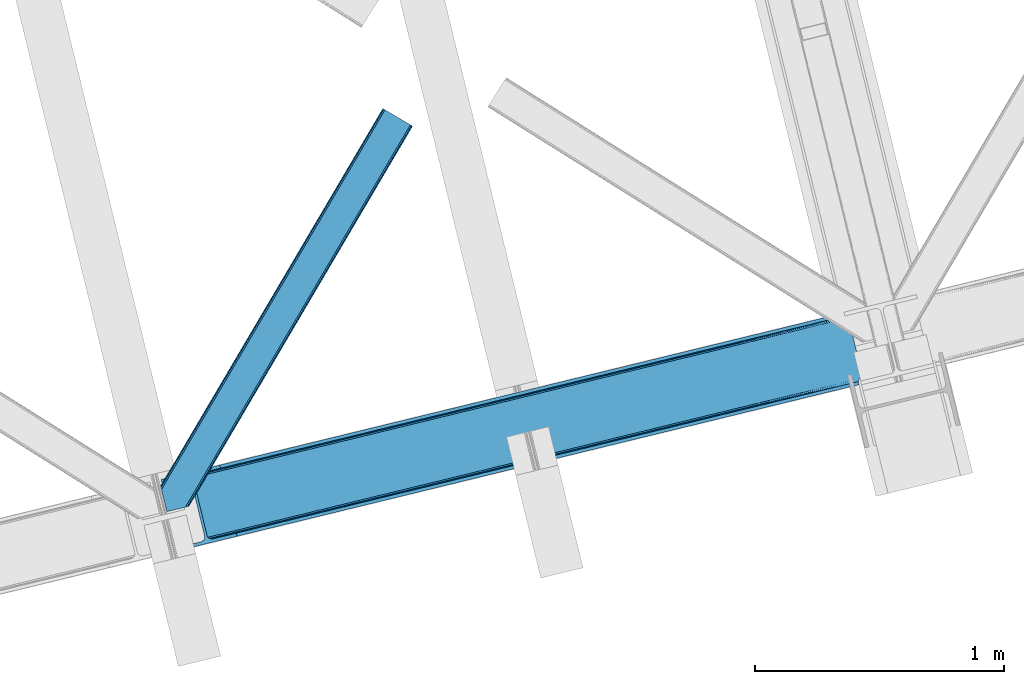
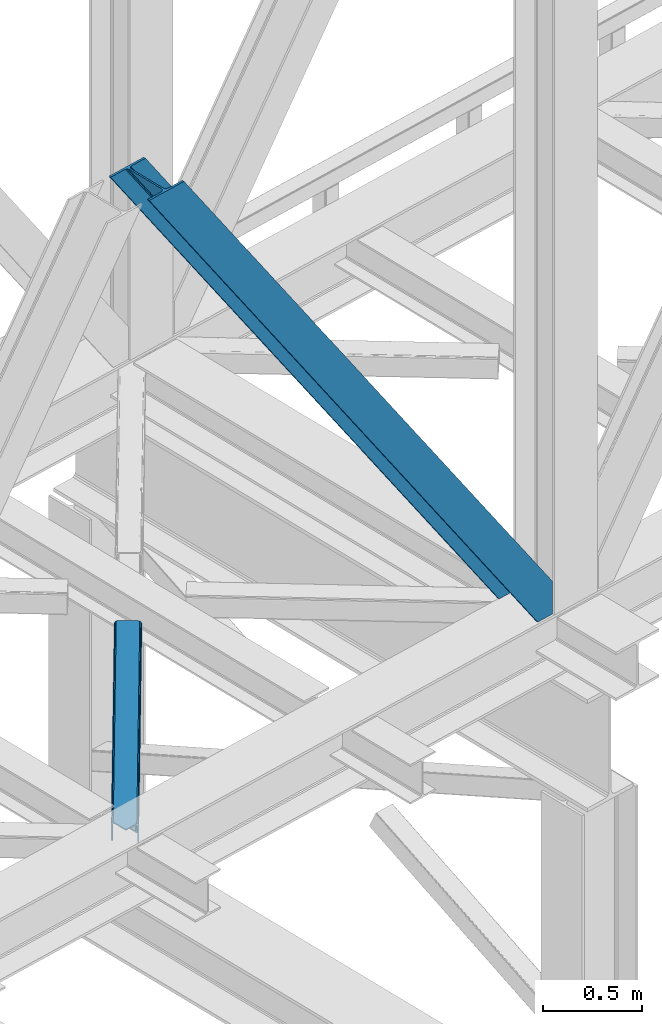
# One storey, part 28 of 92: 2 members.
"""IFC4 building model written with IfcOpenShell, lengths in millimetres."""

from ifc_helpers import new_model, entity, si_unit, converted_unit, derived_unit, direction, frame, origin, place, context, subcontext, project, spatial, triangles, type_object, element, save


model = new_model("IFC4")

# Units and contexts
model_context = context("Model", 3, precision=0.01, world=origin(), true_north=direction((6.12303176911189e-17, 1.0)))
plan_context = context("Plan", 3, precision=0.01, world=origin(), true_north=direction((6.12303176911189e-17, 1.0)))
body_context = subcontext(model_context, "Body", "Model", "MODEL_VIEW")
ifc_project = project(units=[si_unit("LENGTHUNIT", "METRE", prefix="MILLI"), si_unit("AREAUNIT", "SQUARE_METRE"), si_unit("VOLUMEUNIT", "CUBIC_METRE"), converted_unit("PLANEANGLEUNIT", "DEGREE", entity("IfcRatioMeasure", 0.0174532925199433), si_unit("PLANEANGLEUNIT", "RADIAN"), dimensions=[0, 0, 0, 0, 0, 0, 0]), si_unit("MASSUNIT", "GRAM", prefix="KILO"), derived_unit("MASSDENSITYUNIT", [(si_unit("MASSUNIT", "GRAM", prefix="KILO"), 1), (si_unit("LENGTHUNIT", "METRE"), -3)]), derived_unit("MOMENTOFINERTIAUNIT", [(si_unit("LENGTHUNIT", "METRE"), 4)]), si_unit("TIMEUNIT", "SECOND"), si_unit("FREQUENCYUNIT", "HERTZ"), si_unit("THERMODYNAMICTEMPERATUREUNIT", "DEGREE_CELSIUS"), derived_unit("THERMALTRANSMITTANCEUNIT", [(si_unit("MASSUNIT", "GRAM", prefix="KILO"), 1), (si_unit("THERMODYNAMICTEMPERATUREUNIT", "KELVIN"), -1), (si_unit("TIMEUNIT", "SECOND"), -3)]), derived_unit("VOLUMETRICFLOWRATEUNIT", [(si_unit("LENGTHUNIT", "METRE"), 3), (si_unit("TIMEUNIT", "SECOND"), -1)]), derived_unit("MASSFLOWRATEUNIT", [(si_unit("MASSUNIT", "GRAM", prefix="KILO"), 1), (si_unit("TIMEUNIT", "SECOND"), -1)]), derived_unit("ROTATIONALFREQUENCYUNIT", [(si_unit("TIMEUNIT", "SECOND"), -1)]), si_unit("ELECTRICCURRENTUNIT", "AMPERE"), si_unit("ELECTRICVOLTAGEUNIT", "VOLT"), si_unit("POWERUNIT", "WATT"), si_unit("FORCEUNIT", "NEWTON", prefix="KILO"), si_unit("ILLUMINANCEUNIT", "LUX"), si_unit("LUMINOUSFLUXUNIT", "LUMEN"), si_unit("LUMINOUSINTENSITYUNIT", "CANDELA"), derived_unit("USERDEFINED", [(si_unit("MASSUNIT", "GRAM", prefix="KILO"), -1), (si_unit("LENGTHUNIT", "METRE"), -2), (si_unit("TIMEUNIT", "SECOND"), 3), (si_unit("LUMINOUSFLUXUNIT", "LUMEN"), 1)]), derived_unit("LINEARVELOCITYUNIT", [(si_unit("LENGTHUNIT", "METRE"), 1), (si_unit("TIMEUNIT", "SECOND"), -1)]), si_unit("PRESSUREUNIT", "PASCAL"), derived_unit("USERDEFINED", [(si_unit("LENGTHUNIT", "METRE"), -2), (si_unit("MASSUNIT", "GRAM", prefix="KILO"), 1), (si_unit("TIMEUNIT", "SECOND"), -2)]), derived_unit("LINEARFORCEUNIT", [(si_unit("MASSUNIT", "GRAM", prefix="KILO"), 1), (si_unit("LENGTHUNIT", "METRE"), 1), (si_unit("TIMEUNIT", "SECOND"), -2), (si_unit("LENGTHUNIT", "METRE"), -1)]), derived_unit("PLANARFORCEUNIT", [(si_unit("MASSUNIT", "GRAM", prefix="KILO"), 1), (si_unit("LENGTHUNIT", "METRE"), 1), (si_unit("TIMEUNIT", "SECOND"), -2), (si_unit("LENGTHUNIT", "METRE"), -2)])], contexts=[model_context, plan_context])

# Site, building, storey
site_placement = place(None, origin())
site = spatial("IfcSite", under=ifc_project, at=site_placement, CompositionType="ELEMENT")
building_placement = place(site_placement, origin())
building = spatial("IfcBuilding", under=site, at=building_placement, CompositionType="ELEMENT")
storey_placement = place(building_placement, frame((0.0, 0.0, 15900.0)))
storey = spatial("IfcBuildingStorey", under=building, at=storey_placement, Name="05", CompositionType="ELEMENT", Elevation=15900.0)

# Members
member_type_1 = type_object("IfcMemberType", PredefinedType="BRACE")
member_1_placement = place(storey_placement, frame((-57373.99, 3481.27, 3695.0)))
element("IfcMember", 1, at=member_1_placement, inside=storey, type_object=member_type_1, ObjectType="Steel Vertical Brace", PredefinedType="BRACE", context=body_context, shape_type="Tessellation", body=[
    triangles([(2824.17180175781, 696.209248352051, 0.781347656247817), (2824.8368774414, 695.2276222229, 1.0697021484375), (2823.33929443359, 694.862528228759, 0.0), (2821.44638671875, 702.635018920899, 0.0), (2812.37717285156, 692.190598297119, 19.5569458007813), (2812.37717285156, 692.190598297119, 0.0), (2386.756640625, 583.574263000488, 658.75048828125), (2392.34234619141, 580.919773864746, 662.07819213867), (2803.98698730468, 681.26248626709, 51.2480346679658), (2804.11256103515, 683.186496734619, 44.4996093749978), (2382.25924072265, 588.488497924805, 656.525042724606), (2808.48903808594, 690.37995300293, 26.4030395507798), (2805.01948242187, 685.664543151855, 38.2720825195283), (2805.58688964844, 687.218227386475, 34.3676696777329), (630.519653320313, 150.046073913574, 3288.98063964843), (624.69210205078, 150.036772155762, 3285.05529785156), (211.331286621091, 47.8653923034667, 3911.00081176758), (202.862036132814, 47.2113624572753, 3911.00081176758), (619.106396484371, 152.691261291504, 3281.72759399414), (195.034606933594, 49.3190826416017, 3911.00081176758), (614.608996582028, 157.60549621582, 3279.50447387695), (189.039624023433, 53.8679328918456, 3911.00081176758), (611.88358154297, 164.031266784668, 3278.7231262207), (185.788659667967, 60.1655136108398, 3911.00081176758), (2804.10325927734, 679.880593872071, 63.6403015136711), (2398.16524658203, 580.929075622559, 666.003533935545), (1956.25268554688, 473.208325195313, 1321.74955444336), (1950.42978515625, 473.1990234375, 1317.82188720703), (1508.51722412109, 365.478273010254, 1973.56790771484), (1514.34012451172, 365.487574768066, 1977.49324951172), (1066.60466308593, 257.757522583008, 2629.3116027832), (1072.42756347656, 257.76682434082, 2633.23694458008), (1944.84407958984, 475.853512573242, 1314.49418334961), (1502.93151855469, 368.132762145996, 1970.23787841797), (1061.01895751953, 260.41201171875, 2625.98389892578), (1940.3466796875, 480.767747497559, 1312.27106323242), (1498.43411865235, 373.046997070313, 1968.01475830078), (1056.52155761718, 265.326246643067, 2623.75845336914), (2379.53382568359, 594.913977813721, 655.74602050781), (1937.62126464843, 487.193518066406, 1311.48971557617), (1495.70870361328, 379.47276763916, 1967.23341064453), (1053.79614257813, 271.752017211914, 2622.97710571289), (2766.2637084961, 929.006666564941, 0.0), (2324.35114746093, 821.285625457764, 655.74602050781), (1882.43858642578, 713.565165710449, 1311.48971557617), (1440.53067626953, 605.844415283203, 1967.23341064453), (998.618115234371, 498.123664855957, 2622.97710571289), (556.705554199216, 390.402914428711, 3278.7231262207), (130.605981445311, 286.537161254883, 3911.00081176758), (303.265209960933, 70.2747802734375, 3911.00081176758), (2804.10325927734, 679.880593872071, 200.055230712889), (2807.14028320312, 667.239795684814, 200.120343017577), (2804.2985961914, 678.898386383056, 200.120343017577), (306.344091796876, 57.6444465637205, 3911.00081176758), (2807.14028320312, 667.239795684814, 0.0), (2804.2985961914, 678.898386383056, 0.0), (2804.0009399414, 682.092958831787, 0.0), (2804.11256103515, 683.186496734619, 2.42078247070094), (2804.71717529296, 685.456997680664, 5.12991943359157), (2805.58688964844, 687.218227386475, 5.67639770507594), (2807.01470947266, 689.087299346924, 4.89505004882813), (2808.48903808594, 690.37995300293, 3.35328369140552), (2811.03771972656, 691.772309875489, 0.0), (2705.52322998047, 642.46979598999, 0.0), (69.865502929686, 0.0, 3911.00081176758), (2794.37362060547, 677.509226989746, 0.0), (2802.00106201172, 681.140400695801, 0.0), (2702.44434814453, 655.099839019776, 0.0), (66.78662109375, 12.6303337097165, 3911.00081176758), (1480.00268554688, 357.116864776611, 1950.37164916992), (1034.29035644531, 248.469426727295, 2611.75686035156), (588.573376464839, 139.821988677978, 3273.1420715332), (158.715893554683, 35.039430999756, 3911.00081176758), (1925.71501464843, 465.764302825928, 1288.98643798828), (2371.42734375, 574.411740875244, 627.598901367186), (2376.60377197265, 577.083380126953, 631.526568603513), (2380.34307861328, 582.010695648193, 634.854272460936), (2381.53835449219, 595.402610778809, 637.858740234373), (2811.39583740234, 700.184877777099, 0.0), (2811.09353027344, 693.083567047119, 0.0), (2382.0732055664, 588.443733215332, 637.077392578125), (598.679736328122, 160.812567901611, 3283.40191040039), (599.21923828125, 153.853690338135, 3282.62056274414), (175.738110351558, 57.7156631469725, 3911.00081176758), (175.747412109376, 50.6283050537108, 3911.00081176758), (597.489111328126, 147.420943450928, 3280.39744262695), (172.519702148435, 43.8301734924316, 3911.00081176758), (593.749804687497, 142.493627929688, 3277.06973876953), (166.538671875001, 38.3560890197755, 3911.00081176758), (1936.36087646485, 479.796004486084, 1298.46260375976), (1935.82137451172, 486.755172729492, 1299.24395141601), (1490.10904541016, 378.107734680176, 1960.63148803711), (1490.64854736328, 371.148566436767, 1959.85014038086), (1044.93156738281, 262.501128387451, 2621.2353515625), (1044.39671630859, 269.460296630859, 2622.01669921875), (1934.62609863281, 473.363257598877, 1296.23948364258), (1488.91376953125, 364.71581954956, 1957.62469482422), (1043.20144042969, 256.068381500244, 2619.01223144531), (1930.89144287109, 468.435942077637, 1292.91177978515), (1485.17911376953, 359.78850402832, 1954.2969909668), (1039.46213378906, 251.141065979004, 2615.68220214844), (2756.21315917969, 926.556525421142, 0.0), (2326.35567626953, 821.774258422852, 637.858740234373), (1434.9263671875, 604.479382324219, 1960.63148803711), (1880.64334716797, 713.126820373535, 1299.24395141601), (989.214038085935, 495.831944274903, 2622.01669921875), (543.501708984375, 387.184215545654, 3283.40191040039), (120.555432128902, 284.087310791016, 3911.00081176758), (2752.67849121094, 932.72359085083, 0.0), (2753.40867919922, 934.106936645508, 0.0), (2752.02736816406, 933.862474822998, 0.0), (2764.37080078125, 936.778866577149, 0.0), (2753.40867919922, 934.106936645508, 19.5569458007813), (2765.86838378906, 937.143960571289, 1.0697021484375), (2765.72885742188, 935.965544128418, 0.781347656247817), (2325.54642333985, 834.677540588379, 658.75048828125), (2749.12056884765, 933.923517608642, 26.4030395507798), (2745.08825683594, 935.395230102539, 34.3676696777329), (2323.81629638671, 828.244793701172, 656.525042724606), (2743.51160888671, 936.560275268555, 38.5441589355469), (556.166052246095, 397.361791992188, 3279.50447387695), (130.5966796875, 293.624228668213, 3911.00081176758), (557.900830078121, 403.794829559326, 3281.72759399414), (133.824389648435, 300.422360229492, 3911.00081176758), (561.635485839841, 408.721854400635, 3285.05529785156), (139.805419921875, 305.896444702149, 3911.00081176758), (566.811914062499, 411.393493652344, 3288.98063964843), (147.628198242186, 309.213102722168, 3911.00081176758), (2740.93037109375, 939.947568511963, 51.2480346679658), (2740.39552001953, 941.228304290771, 63.6403015136711), (2329.28572998047, 839.60485610962, 662.07819213867), (2334.45750732422, 842.276495361328, 666.003533935545), (2742.09309082031, 938.42149887085, 45.5251281738274), (1881.90373535156, 720.524043273926, 1312.27106323242), (1439.9911743164, 612.80329284668, 1968.01475830078), (998.07861328125, 505.082542419434, 2623.75845336914), (1883.63386230468, 726.956790161133, 1314.49418334961), (1441.72130126953, 619.236039733887, 1970.23787841797), (999.813391113283, 511.515289306641, 2625.98389892578), (1887.37316894531, 731.884105682373, 1317.82188720703), (1445.46060791016, 624.163355255127, 1973.56790771484), (1003.548046875, 516.442604827881, 2629.3116027832), (1892.54959716797, 734.555744934082, 1321.74955444336), (1450.63703613281, 626.834994506836, 1977.49324951172), (1008.72447509765, 519.11424407959, 2633.23694458008), (2740.39552001953, 941.228304290771, 200.055230712889), (239.557470703126, 331.622200012207, 3911.00081176758), (2749.12056884765, 933.923517608642, 3.35328369140552), (2745.08825683594, 935.395230102539, 5.67639770507594), (2747.2230102539, 934.392675018311, 4.89272460937354), (2743.51160888671, 936.560275268555, 5.12991943359157), (2740.11646728515, 942.189001464843, 0.0), (2741.92565917969, 938.297378540039, 2.42078247070094), (2740.11646728515, 942.189001464843, 200.120343017577), (2741.32104492188, 939.215927124023, 0.0), (2323.63026123046, 828.2000289917, 637.077392578125), (2319.13286132812, 833.113973236084, 634.854272460936), (2313.54715576172, 835.768462371826, 631.526568603513), (2307.72425537109, 835.759160614014, 627.598901367186), (2730.67053222656, 938.856646728515, 0.0), (2739.1072265625, 939.141222381591, 0.0), (524.870288085935, 401.16969909668, 3273.1420715332), (530.693188476558, 401.17871017456, 3277.06973876953), (103.477404785153, 297.041171264648, 3911.00081176758), (95.0081542968765, 296.387141418457, 3911.00081176758), (536.278894042967, 398.524221038818, 3280.39744262695), (111.309484863283, 294.933451080322, 3911.00081176758), (540.77629394531, 393.609986114502, 3282.62056274414), (117.304467773436, 290.384600830078, 3911.00081176758), (1867.83482666015, 727.12102432251, 1292.91177978515), (1862.01192626953, 727.112013244629, 1288.98643798828), (1416.29494628906, 618.464575195312, 1950.37164916992), (1422.11784667968, 618.473586273193, 1954.2969909668), (970.582617187501, 509.817137145996, 2611.75686035156), (976.405517578125, 509.826148223877, 2615.68220214844), (1873.42053222656, 724.466535186768, 1296.23948364258), (1427.70355224609, 615.819097137452, 1957.62469482422), (981.991223144527, 507.171659088135, 2619.01223144531), (1877.9179321289, 719.552300262451, 1298.46260375976), (1432.20560302735, 610.905152893066, 1959.85014038086), (986.488623046876, 502.257424163819, 2621.2353515625), (2737.27478027344, 953.847592163086, 200.120343017577), (236.478588867183, 344.252533721924, 3911.00081176758), (2737.27478027344, 953.847592163086, 0.0), (0.0, 286.608087158203, 3911.00081176758), (3.07888183593604, 273.977753448487, 3911.00081176758), (2635.65772705078, 929.077592468262, 0.0), (2638.73660888672, 916.447258758545, 0.0)], [[1, 2, 3], [3, 4, 1], [2, 5, 6], [6, 3, 2], [7, 8, 9], [9, 10, 7], [11, 12, 5], [5, 1, 11], [5, 2, 1], [11, 7, 13], [13, 14, 11], [14, 12, 11], [15, 16, 17], [18, 17, 16], [16, 19, 18], [20, 18, 19], [19, 21, 20], [22, 20, 21], [21, 23, 22], [24, 22, 23], [10, 13, 7], [25, 9, 8], [8, 26, 25], [26, 8, 27], [28, 27, 8], [27, 28, 29], [29, 30, 27], [30, 29, 31], [31, 32, 30], [32, 31, 16], [16, 15, 32], [8, 7, 28], [33, 28, 7], [28, 33, 29], [34, 29, 33], [29, 34, 31], [35, 31, 34], [31, 35, 19], [19, 16, 31], [7, 11, 36], [36, 33, 7], [33, 36, 37], [37, 34, 33], [34, 37, 35], [38, 35, 37], [35, 38, 19], [21, 19, 38], [1, 4, 39], [39, 11, 1], [11, 39, 40], [40, 36, 11], [36, 40, 41], [41, 37, 36], [37, 41, 42], [42, 38, 37], [38, 42, 21], [23, 21, 42], [4, 43, 44], [45, 39, 44], [41, 40, 45], [41, 45, 46], [44, 39, 4], [45, 40, 39], [42, 41, 46], [46, 47, 42], [47, 48, 23], [49, 24, 48], [47, 23, 42], [48, 24, 23], [50, 51, 30], [30, 32, 50], [32, 15, 50], [17, 50, 15], [27, 30, 51], [51, 25, 26], [26, 27, 51], [52, 53, 54], [53, 51, 50], [50, 54, 53], [52, 55, 53], [56, 53, 55], [56, 9, 25], [56, 57, 58], [58, 10, 56], [10, 9, 56], [59, 60, 14], [14, 13, 59], [10, 58, 59], [60, 61, 12], [12, 14, 60], [5, 62, 63], [63, 6, 5], [5, 12, 62], [61, 62, 12], [13, 10, 59], [25, 51, 53], [53, 56, 25], [54, 64, 52], [54, 65, 64], [64, 55, 52], [56, 66, 67], [55, 66, 56], [67, 57, 56], [64, 66, 55], [64, 68, 66], [68, 64, 65], [65, 69, 68], [69, 70, 68], [71, 69, 72], [69, 71, 70], [69, 73, 72], [74, 68, 70], [66, 68, 75], [74, 75, 68], [67, 76, 58], [76, 77, 59], [59, 58, 76], [76, 67, 66], [78, 79, 80], [81, 60, 59], [81, 80, 62], [62, 61, 81], [61, 60, 81], [80, 63, 62], [59, 77, 81], [80, 81, 78], [82, 83, 84], [85, 84, 83], [83, 86, 85], [87, 85, 86], [86, 88, 87], [89, 87, 88], [88, 72, 89], [73, 89, 72], [66, 75, 76], [58, 57, 67], [78, 81, 90], [90, 91, 78], [91, 90, 92], [93, 92, 90], [92, 93, 94], [94, 95, 92], [95, 94, 83], [83, 82, 95], [81, 77, 90], [96, 90, 77], [90, 96, 93], [97, 93, 96], [93, 97, 94], [98, 94, 97], [94, 98, 83], [86, 83, 98], [77, 76, 99], [99, 96, 77], [96, 99, 100], [100, 97, 96], [97, 100, 101], [101, 98, 97], [98, 101, 86], [88, 86, 101], [76, 75, 99], [74, 99, 75], [99, 74, 70], [70, 100, 99], [100, 70, 71], [71, 101, 100], [101, 71, 88], [72, 88, 71], [102, 79, 78], [91, 103, 78], [104, 105, 91], [104, 91, 92], [78, 103, 102], [91, 105, 103], [106, 104, 92], [92, 95, 106], [95, 82, 107], [84, 108, 82], [95, 107, 106], [82, 108, 107], [109, 102, 110], [6, 79, 80], [6, 80, 63], [110, 111, 109], [3, 79, 6], [79, 4, 102], [3, 4, 79], [43, 102, 4], [102, 112, 110], [112, 102, 43], [113, 114, 110], [112, 110, 114], [114, 115, 112], [43, 112, 115], [116, 117, 118], [119, 115, 113], [113, 116, 119], [113, 117, 116], [115, 114, 113], [118, 120, 116], [48, 121, 122], [122, 49, 48], [121, 123, 124], [124, 122, 121], [123, 125, 126], [126, 124, 123], [125, 127, 128], [128, 126, 125], [129, 130, 131], [132, 131, 130], [133, 116, 120], [116, 133, 129], [131, 116, 129], [43, 115, 119], [119, 44, 43], [44, 119, 45], [134, 45, 119], [45, 134, 46], [135, 46, 134], [46, 135, 47], [136, 47, 135], [47, 136, 121], [121, 48, 47], [119, 116, 134], [137, 134, 116], [134, 137, 135], [138, 135, 137], [135, 138, 139], [139, 136, 135], [136, 139, 121], [123, 121, 139], [116, 131, 140], [140, 137, 116], [137, 140, 141], [141, 138, 137], [138, 141, 142], [142, 139, 138], [139, 142, 123], [125, 123, 142], [131, 132, 140], [143, 140, 132], [140, 143, 141], [144, 141, 143], [141, 144, 142], [145, 142, 144], [142, 145, 125], [127, 125, 145], [144, 146, 147], [147, 127, 145], [127, 147, 128], [145, 144, 147], [146, 144, 143], [143, 132, 146], [130, 146, 132], [113, 110, 111], [148, 117, 113], [149, 118, 117], [117, 148, 150], [151, 133, 120], [118, 149, 151], [151, 120, 118], [152, 133, 153], [152, 129, 133], [146, 130, 154], [152, 154, 130], [130, 129, 152], [153, 155, 152], [151, 153, 133], [117, 150, 149], [111, 148, 113], [156, 150, 148], [156, 149, 150], [148, 109, 156], [148, 111, 109], [156, 157, 151], [151, 149, 156], [103, 156, 109], [158, 159, 160], [158, 153, 151], [158, 161, 153], [161, 155, 153], [151, 157, 158], [160, 161, 158], [162, 163, 164], [164, 165, 162], [163, 166, 167], [167, 164, 163], [166, 168, 169], [169, 167, 166], [168, 107, 108], [108, 169, 168], [109, 102, 103], [159, 158, 170], [170, 171, 159], [171, 170, 172], [173, 172, 170], [172, 173, 174], [175, 174, 173], [174, 175, 162], [163, 162, 175], [158, 157, 170], [176, 170, 157], [170, 176, 173], [177, 173, 176], [173, 177, 175], [178, 175, 177], [175, 178, 166], [166, 163, 175], [157, 156, 179], [179, 176, 157], [176, 179, 180], [180, 177, 176], [177, 180, 181], [181, 178, 177], [178, 181, 166], [168, 166, 181], [156, 103, 179], [105, 179, 103], [179, 105, 104], [104, 180, 179], [180, 104, 181], [106, 181, 104], [181, 106, 168], [107, 168, 106], [146, 154, 147], [154, 182, 183], [183, 147, 154], [154, 152, 184], [184, 182, 154], [108, 84, 49], [87, 89, 18], [73, 65, 54], [69, 65, 73], [89, 73, 17], [84, 85, 22], [85, 87, 20], [167, 126, 164], [185, 165, 183], [165, 164, 128], [185, 186, 165], [167, 169, 124], [169, 108, 122], [49, 84, 24], [17, 18, 89], [22, 85, 20], [18, 20, 87], [22, 24, 84], [54, 17, 73], [54, 50, 17], [128, 164, 126], [124, 169, 122], [49, 122, 108], [124, 126, 167], [128, 183, 165], [183, 128, 147], [152, 160, 184], [155, 161, 152], [152, 161, 160], [160, 187, 184], [187, 160, 188], [183, 187, 185], [187, 183, 182], [184, 187, 182], [172, 186, 188], [162, 186, 174], [162, 165, 186], [172, 174, 186], [188, 171, 172], [159, 171, 188], [188, 160, 159], [187, 188, 185], [186, 185, 188]]),
])
member_type_2 = type_object("IfcMemberType", PredefinedType="BRACE")
member_2_placement = place(storey_placement, frame((-57375.4, 3638.1, 3511.0)))
element("IfcMember", 2, at=member_2_placement, inside=storey, type_object=member_type_2, ObjectType="Steel Horizontal Brace", PredefinedType="BRACE", context=body_context, shape_type="Tessellation", body=[
    triangles([(154.446386718751, 124.708666992188, 0.0), (118.769494628905, 271.071535491943, 0.0), (998.971582031249, 1559.19843292236, 0.0), (908.488732910155, 1612.46901855469, 0.0), (1004.74332275391, 1555.80096588135, 1.33247680664135), (156.725317382814, 115.37377166748, 1.33247680664135), (1009.63604736328, 1552.92090911865, 5.12526855468968), (158.650781249999, 107.459719848633, 5.12526855468968), (1012.90561523438, 1550.99602661133, 10.8028289794929), (159.943725585938, 102.171670532227, 10.8028289794929), (1014.05438232422, 1550.3204864502, 17.5000946044929), (160.394860839842, 100.314807128907, 17.5000946044929), (902.716992187503, 1615.8664855957, 1.33247680664135), (116.495214843751, 280.406721496582, 1.33247680664135), (114.574401855469, 288.275717926026, 5.17061462402489), (897.824267578122, 1618.74712371826, 5.12526855468968), (114.499987792966, 288.596628570557, 5.32641906738354), (894.554699707034, 1620.67142486572, 10.8028289794929), (109.625866699222, 287.409201049805, 10.8028289794929), (893.405932617185, 1621.34696502686, 17.5000946044929), (107.821325683595, 286.969111633301, 17.5000946044929), (113.527954101563, 288.35972442627, 18.5197998046897), (114.499987792966, 288.596628570557, 17.5198608398459), (114.42557373047, 288.578606414795, 17.9023956298843), (114.216284179689, 288.527156066895, 18.2279571533218), (113.900024414063, 288.450416564941, 18.4442230224631), (107.821325683595, 286.969111633301, 18.5197998046897), (115.695263671878, 283.683556365967, 17.5198608398459), (115.625500488284, 283.800409698486, 17.8035644531265), (115.565039062501, 283.740529632569, 17.8570495605491), (115.323193359378, 283.495777130127, 18.0768035888686), (115.067395019534, 283.23939743042, 18.3081848144539), (114.834851074222, 283.003074645996, 18.5197998046897), (0.0, 103.824767303467, 18.5197998046897), (2.73471679687646, 92.5989990234375, 18.5197998046897), (893.405932617185, 1621.34696502686, 122.500662231447), (0.0, 103.824767303467, 122.500662231447), (908.488732910155, 1612.46901855469, 139.999594116212), (902.716992187503, 1615.8664855957, 138.667117309571), (3.66954345702834, 88.7660934448245, 138.667117309571), (5.94847412109084, 79.4309074401858, 139.999594116212), (897.824267578122, 1618.74712371826, 134.874325561526), (1.73942871093459, 96.6798545837405, 134.874325561526), (894.554699707034, 1620.67142486572, 129.197927856447), (0.451135253904795, 101.967903900147, 129.197927856447), (899.438122558597, 1617.79601898193, 24.4996673583992), (2.37659912109666, 94.0672233581545, 24.4996673583992), (900.586889648439, 1617.11989746094, 17.8035644531265), (903.856457519534, 1615.19559631348, 12.1260040283232), (914.52092285156, 1608.9174911499, 6.99957275390625), (908.749182128908, 1612.31495819092, 8.3320495605476), (118.871813964841, 270.64917755127, 8.3320495605476), (121.150744628903, 261.313991546631, 6.99957275390625), (116.946350097656, 278.562938690186, 12.1260040283232), (152.069787597655, 134.4662109375, 6.99957275390625), (992.939392089844, 1562.74996032715, 6.99957275390625), (156.274182128909, 117.217263793946, 12.1260040283232), (154.344067382815, 125.131024932862, 8.3320495605476), (157.520617675778, 112.096646118164, 17.5198608398459), (160.394860839842, 100.314807128907, 17.5198608398459), (899.438122558597, 1617.79601898193, 115.501089477541), (2.37659912109666, 94.0672233581545, 115.501089477541), (900.586889648439, 1617.11989746094, 122.196029663086), (2.83238525390334, 92.2103599548341, 122.196029663086), (903.856457519534, 1615.19559631348, 127.87475280762), (4.12067871094041, 86.9223106384279, 127.87475280762), (908.749182128908, 1612.31495819092, 131.667544555665), (6.05079345703416, 79.0085494995119, 131.667544555665), (914.52092285156, 1608.9174911499, 133.000021362306), (8.3250732421875, 69.6733634948732, 133.000021362306), (25.310083007811, 0.0, 133.000021362306), (25.310083007811, 0.0, 139.999594116212), (90.3665771484375, 15.8580436706543, 139.999594116212), (998.971582031249, 1559.19843292236, 139.999594116212), (1014.05438232422, 1550.3204864502, 122.500662231447), (1012.90561523438, 1550.99602661133, 129.197927856447), (114.076757812501, 21.6376327514649, 122.500662231447), (112.267565917966, 21.1978340148926, 129.197927856447), (1009.63604736328, 1552.92090911865, 134.874325561526), (107.12834472656, 19.9450035095215, 134.874325561526), (1004.74332275391, 1555.80096588135, 138.667117309571), (99.435791015625, 18.0698272705081, 138.667117309571), (159.664672851563, 99.0785453796389, 18.5197998046897), (114.076757812501, 21.6376327514649, 18.5197998046897), (103.161145019534, 18.9779113769532, 18.5197998046897), (156.929956054686, 110.304313659668, 18.5197998046897), (1008.02219238281, 1553.87143249512, 24.4996673583992), (1006.87342529297, 1554.54755401611, 17.8035644531265), (1003.60385742188, 1556.47185516357, 12.1260040283232), (998.711132812503, 1559.35249328613, 8.3320495605476), (104.588964843751, 19.325855255127, 24.4996673583992), (1003.60385742188, 1556.47185516357, 127.87475280762), (1008.02219238281, 1553.87143249512, 115.501089477541), (1006.87342529297, 1554.54755401611, 122.196029663086), (992.939392089844, 1562.74996032715, 133.000021362306), (998.711132812503, 1559.35249328613, 131.667544555665), (102.784423828125, 18.8860565185546, 122.196029663086), (80.8787841796875, 13.5462661743163, 133.000021362306), (89.9526489257842, 15.7580497741701, 131.667544555665), (97.6452026367188, 17.6329353332521, 127.87475280762), (104.588964843751, 19.325855255127, 115.501089477541)], [[1, 2, 3], [4, 3, 2], [3, 5, 1], [6, 1, 5], [5, 7, 6], [8, 6, 7], [7, 9, 8], [10, 8, 9], [9, 11, 10], [12, 10, 11], [13, 14, 15], [16, 15, 17], [17, 18, 16], [17, 19, 18], [20, 18, 19], [19, 21, 20], [15, 16, 13], [13, 4, 14], [2, 14, 4], [22, 23, 24], [22, 25, 26], [27, 21, 22], [24, 25, 22], [23, 22, 21], [21, 19, 23], [17, 23, 19], [23, 28, 29], [29, 24, 23], [25, 24, 30], [26, 25, 31], [22, 26, 32], [32, 33, 22], [31, 32, 26], [30, 31, 25], [29, 30, 24], [34, 33, 35], [33, 34, 27], [22, 33, 27], [27, 20, 21], [36, 27, 37], [27, 36, 20], [27, 34, 37], [38, 39, 40], [40, 41, 38], [39, 42, 43], [43, 40, 39], [42, 44, 45], [45, 43, 42], [44, 36, 37], [37, 45, 44], [46, 47, 33], [33, 48, 46], [33, 31, 48], [47, 35, 33], [49, 48, 28], [50, 51, 52], [52, 53, 50], [51, 49, 54], [54, 52, 51], [28, 54, 49], [53, 55, 56], [56, 50, 53], [55, 2, 1], [54, 17, 14], [52, 14, 2], [52, 2, 53], [55, 53, 2], [17, 28, 23], [54, 28, 17], [52, 54, 14], [57, 58, 6], [58, 1, 6], [1, 58, 55], [8, 57, 6], [8, 59, 57], [10, 59, 8], [10, 60, 59], [46, 61, 47], [62, 47, 61], [61, 63, 62], [64, 62, 63], [63, 65, 64], [66, 64, 65], [65, 67, 66], [68, 66, 67], [67, 69, 68], [70, 68, 69], [66, 43, 64], [71, 72, 70], [72, 41, 70], [40, 68, 41], [66, 68, 40], [68, 70, 41], [66, 40, 43], [37, 34, 62], [45, 64, 43], [62, 64, 37], [64, 45, 37], [34, 47, 62], [34, 35, 47], [41, 73, 74], [73, 41, 72], [74, 38, 41], [75, 76, 77], [78, 77, 76], [76, 79, 78], [80, 78, 79], [79, 81, 80], [82, 80, 81], [81, 74, 82], [73, 82, 74], [60, 75, 77], [60, 11, 75], [77, 83, 60], [77, 84, 83], [84, 85, 83], [86, 83, 85], [87, 88, 59], [88, 89, 57], [57, 59, 88], [89, 90, 58], [58, 57, 89], [90, 56, 55], [55, 58, 90], [87, 86, 91], [85, 91, 86], [9, 89, 88], [87, 75, 11], [9, 88, 11], [9, 7, 89], [88, 87, 11], [89, 7, 5], [56, 3, 4], [3, 90, 5], [90, 3, 56], [90, 89, 5], [76, 92, 79], [93, 75, 87], [75, 94, 76], [94, 75, 93], [76, 94, 92], [74, 95, 38], [81, 79, 92], [92, 96, 81], [96, 95, 74], [74, 81, 96], [49, 13, 16], [4, 50, 56], [4, 51, 50], [51, 4, 13], [49, 51, 13], [46, 20, 36], [18, 48, 49], [16, 18, 49], [48, 18, 20], [46, 48, 20], [39, 65, 42], [38, 95, 69], [69, 67, 38], [67, 65, 39], [39, 38, 67], [44, 42, 65], [36, 61, 46], [63, 36, 44], [36, 63, 61], [63, 44, 65], [97, 78, 80], [98, 73, 72], [72, 71, 98], [98, 99, 73], [99, 82, 73], [100, 82, 99], [80, 82, 100], [97, 77, 78], [101, 77, 97], [80, 100, 97], [84, 91, 85], [101, 84, 77], [91, 84, 101], [98, 70, 95], [98, 71, 70], [69, 95, 70], [95, 96, 99], [99, 98, 95], [96, 92, 100], [100, 99, 96], [92, 94, 97], [97, 100, 92], [94, 93, 101], [101, 97, 94], [93, 87, 91], [91, 101, 93]]),
])

save(model, "model.ifc")
